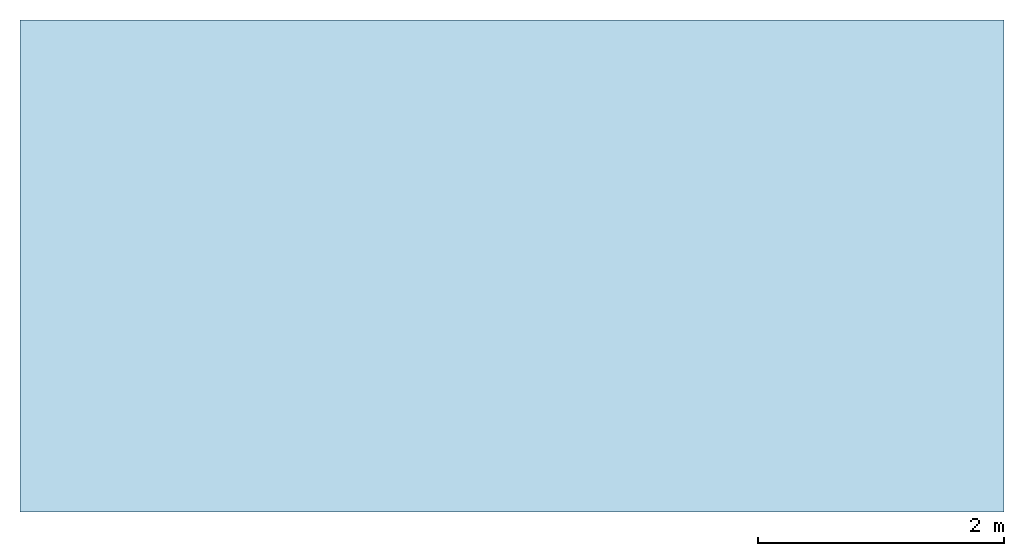
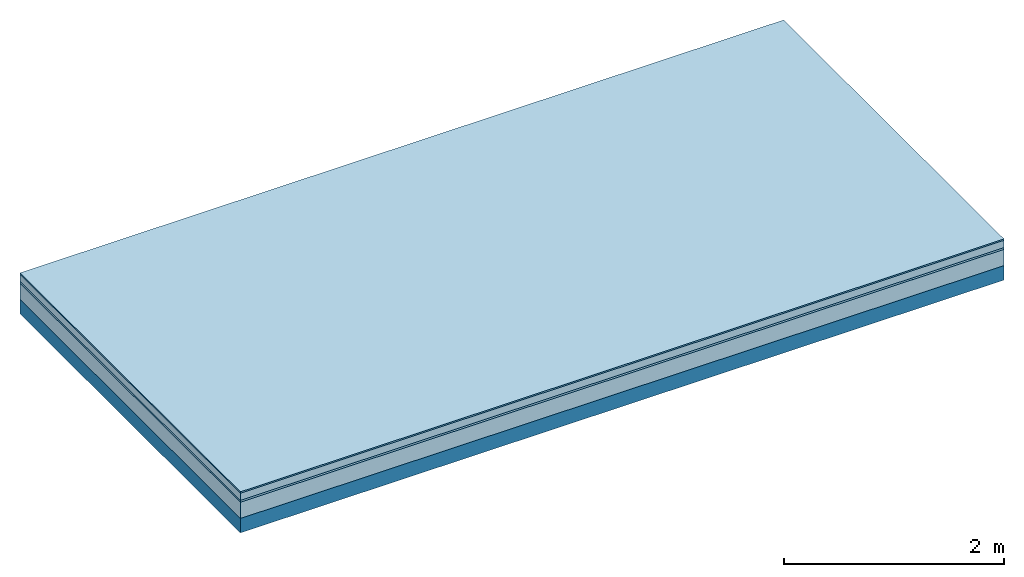
# One storey: 4 plates, 1 member, 1 element without a shape of its own.
"""IFC4 building model written with IfcOpenShell, lengths in metres."""

from ifc_helpers import new_model, si_unit, derived_unit, direction, frame, frame_2d, origin, origin_with_axes, place, context, project, spatial, rectangle, extrude, material, layer, layer_set, type_object, element, aggregate, save


model = new_model("IFC4")

# Units and contexts
plan_context = context("Plan", 3, precision=1e-05, world=origin(), true_north=direction((0.0, 1.0)))
model_context = context("Model", 3, precision=1e-05, world=origin(), true_north=direction((0.0, 1.0)))
ifc_project = project(units=[si_unit("LENGTHUNIT", "METRE"), derived_unit("SOUNDPRESSUREUNIT", [(si_unit("PRESSUREUNIT", "PASCAL", prefix="MICRO"), 0)]), si_unit("ENERGYUNIT", "JOULE", prefix="MEGA"), si_unit("MASSUNIT", "GRAM", prefix="KILO"), derived_unit("THERMALTRANSMITTANCEUNIT", [(si_unit("POWERUNIT", "WATT"), 1), (si_unit("AREAUNIT", "SQUARE_METRE"), -1), (si_unit("THERMODYNAMICTEMPERATUREUNIT", "KELVIN"), -1)]), derived_unit("AREADENSITYUNIT", [(si_unit("MASSUNIT", "GRAM", prefix="KILO"), 1), (si_unit("AREAUNIT", "SQUARE_METRE"), -1)]), derived_unit("USERDEFINED", [(si_unit("ENERGYUNIT", "JOULE", prefix="MEGA"), 1), (si_unit("AREAUNIT", "SQUARE_METRE"), -1)])], contexts=[plan_context, model_context])

# Site, building, storey
site = spatial("IfcSite", under=ifc_project)
building_placement = place(None, origin())
building = spatial("IfcBuilding", under=site, at=building_placement)
storey_placement = place(building_placement, origin())
storey = spatial("IfcBuildingStorey", under=building, at=storey_placement)

# Slab, member, plates
ifc_material_1 = material(Category="11.013")
ifc_layer_1 = layer(ifc_material_1, 0.015, Name="Flooring")
ifc_material_2 = material(Name="Cement screed", Category="04.006")
ifc_layer_2 = layer(ifc_material_2, 0.08, Name="On-material")
ifc_material_3 = material(Name="Wood fiber generic product", Category="10.009")
ifc_layer_3 = layer(ifc_material_3, 0.02, Name="Impact sound insulation")
ifc_material_4 = material(Category="10.006")
ifc_layer_4 = layer(ifc_material_4, 0.18, Name="Additional insulation")
ifc_material_5 = material(Name="no composite action")
ifc_layer_5 = layer(ifc_material_5, 0.0, Name="Bond")
ifc_layer_6 = layer(None, 0.16, Name="Supporting structure")
ifc_material_6 = material(Name="of the art")
ifc_layer_7 = layer(ifc_material_6, 0.0, Name="Bond")
ifc_layer_set = layer_set([ifc_layer_1, ifc_layer_2, ifc_layer_3, ifc_layer_4, ifc_layer_5, ifc_layer_6, ifc_layer_7])
slab_type = type_object("IfcSlabType", Name="A2184", PredefinedType="NOTDEFINED", material=ifc_layer_set)
slab_placement = place(None, frame((0.0, 0.0, 0.0), z_axis=(0.0, 0.0, -1.0), x_axis=(1.0, 0.0, 0.0)))
slab = element("IfcSlab", 1, at=slab_placement, inside=storey, type_object=slab_type, material=ifc_layer_set, Name="Slab #1")
ifc_material_7 = material(Name="Solid timber panel")
member_placement = place(slab_placement, origin())
member = element("IfcMember", 2, at=member_placement, material=ifc_material_7, Name="Supporting structure", context=plan_context, shape_type="SweptSolid", body=[
    extrude(rectangle(XDim=1.0, YDim=0.16, at=frame_2d((0.5, 0.08), x_axis=(1.0, 0.0))), frame((0.0, 4.0, 0.295), z_axis=(0.0, -1.0, 0.0), x_axis=(1.0, 0.0, 0.0)), (0.0, 0.0, 1.0), 4.0),
    extrude(rectangle(XDim=1.0, YDim=0.16, at=frame_2d((0.5, 0.08), x_axis=(1.0, 0.0))), frame((1.0, 4.0, 0.295), z_axis=(0.0, -1.0, 0.0), x_axis=(1.0, 0.0, 0.0)), (0.0, 0.0, 1.0), 4.0),
    extrude(rectangle(XDim=1.0, YDim=0.16, at=frame_2d((0.5, 0.08), x_axis=(1.0, 0.0))), frame((2.0, 4.0, 0.295), z_axis=(0.0, -1.0, 0.0), x_axis=(1.0, 0.0, 0.0)), (0.0, 0.0, 1.0), 4.0),
    extrude(rectangle(XDim=1.0, YDim=0.16, at=frame_2d((0.5, 0.08), x_axis=(1.0, 0.0))), frame((3.0, 4.0, 0.295), z_axis=(0.0, -1.0, 0.0), x_axis=(1.0, 0.0, 0.0)), (0.0, 0.0, 1.0), 4.0),
    extrude(rectangle(XDim=1.0, YDim=0.16, at=frame_2d((0.5, 0.08), x_axis=(1.0, 0.0))), frame((4.0, 4.0, 0.295), z_axis=(0.0, -1.0, 0.0), x_axis=(1.0, 0.0, 0.0)), (0.0, 0.0, 1.0), 4.0),
    extrude(rectangle(XDim=1.0, YDim=0.16, at=frame_2d((0.5, 0.08), x_axis=(1.0, 0.0))), frame((5.0, 4.0, 0.295), z_axis=(0.0, -1.0, 0.0), x_axis=(1.0, 0.0, 0.0)), (0.0, 0.0, 1.0), 4.0),
    extrude(rectangle(XDim=1.0, YDim=0.16, at=frame_2d((0.5, 0.08), x_axis=(1.0, 0.0))), frame((6.0, 4.0, 0.295), z_axis=(0.0, -1.0, 0.0), x_axis=(1.0, 0.0, 0.0)), (0.0, 0.0, 1.0), 4.0),
    extrude(rectangle(XDim=1.0, YDim=0.16, at=frame_2d((0.5, 0.08), x_axis=(1.0, 0.0))), frame((7.0, 4.0, 0.295), z_axis=(0.0, -1.0, 0.0), x_axis=(1.0, 0.0, 0.0)), (0.0, 0.0, 1.0), 4.0),
])
plate_1_placement = place(slab_placement, origin())
plate_1 = element("IfcPlate", 3, at=plate_1_placement, material=ifc_material_1, Name="Flooring", context=plan_context, shape_type="SweptSolid", body=[
    extrude(rectangle(XDim=8.0, YDim=4.0, at=frame_2d((4.0, 2.0), x_axis=(1.0, 0.0))), origin_with_axes(), (0.0, 0.0, 1.0), 0.015),
])
plate_2_placement = place(slab_placement, origin())
plate_2 = element("IfcPlate", 4, at=plate_2_placement, material=ifc_material_2, Name="On-material", context=plan_context, shape_type="SweptSolid", body=[
    extrude(rectangle(XDim=8.0, YDim=4.0, at=frame_2d((4.0, 2.0), x_axis=(1.0, 0.0))), frame((0.0, 0.0, 0.015), z_axis=(0.0, 0.0, 1.0), x_axis=(1.0, 0.0, 0.0)), (0.0, 0.0, 1.0), 0.08),
])
plate_3_placement = place(slab_placement, origin())
plate_3 = element("IfcPlate", 5, at=plate_3_placement, material=ifc_material_3, Name="Impact sound insulation", context=plan_context, shape_type="SweptSolid", body=[
    extrude(rectangle(XDim=8.0, YDim=4.0, at=frame_2d((4.0, 2.0), x_axis=(1.0, 0.0))), frame((0.0, 0.0, 0.095), z_axis=(0.0, 0.0, 1.0), x_axis=(1.0, 0.0, 0.0)), (0.0, 0.0, 1.0), 0.02),
])
plate_4_placement = place(slab_placement, origin())
plate_4 = element("IfcPlate", 6, at=plate_4_placement, material=ifc_material_4, Name="Additional insulation", context=plan_context, shape_type="SweptSolid", body=[
    extrude(rectangle(XDim=8.0, YDim=4.0, at=frame_2d((4.0, 2.0), x_axis=(1.0, 0.0))), frame((0.0, 0.0, 0.115), z_axis=(0.0, 0.0, 1.0), x_axis=(1.0, 0.0, 0.0)), (0.0, 0.0, 1.0), 0.18),
])
aggregate(slab, [plate_1, plate_2, plate_3, plate_4, member])

save(model, "model.ifc")
